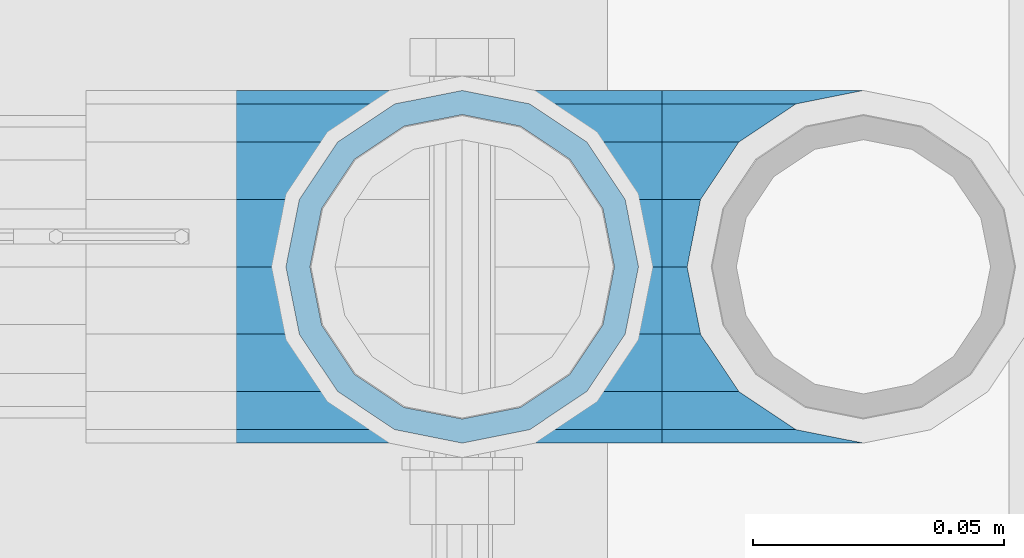
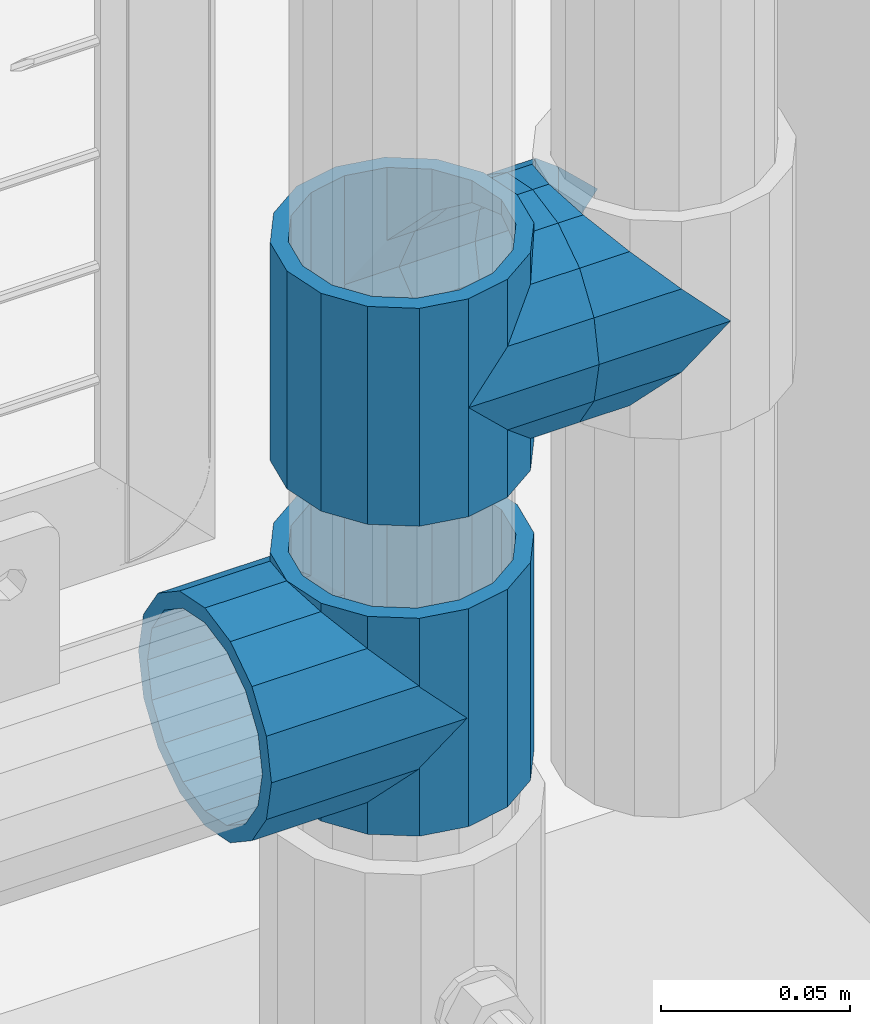
# One storey, part 149 of 219: 5 beams.
"""IFC2X3 building model written with IfcOpenShell, lengths in millimetres."""

import ifcopenshell
import ifcopenshell.guid

model = None  # the IFC model being written
_history = None  # IfcOwnerHistory: only IFC2X3 demands one
_inside = {}  # id of a spatial element -> (the spatial element, [elements in it])
_under = {}  # id of a project, library or spatial element -> (it, [spatial elements below it])
_declared = {}  # id of a project -> (the project, [libraries it declares])
_typed = {}  # id of a type object -> (the type object, [elements of that type])
_made_of = {}  # id of a material, layer set ... -> (it, [elements and type objects made of it])


def new_model(schema):
    """Start an empty IFC model of exactly this schema.

    Asked for "IFC4X3", IfcOpenShell would pick the latest addendum, in which some entities
    have other attributes; the version numbers below select the first issue.
    IFC2X3 requires an IfcOwnerHistory on every rooted entity: one is made here for all.
    """
    global model, _history
    if schema == "IFC4X3":
        model = ifcopenshell.file(schema_version=(4, 3, 0, 0))
    else:
        model = ifcopenshell.file(schema=schema)
    _inside.clear()
    _under.clear()
    _declared.clear()
    _typed.clear()
    _made_of.clear()
    _history = None
    if model.schema == "IFC2X3":
        org = make("IfcOrganization", Name="unknown")
        user = make(
            "IfcPersonAndOrganization",
            ThePerson=make("IfcPerson", FamilyName="unknown"),
            TheOrganization=org,
        )
        app = make(
            "IfcApplication",
            ApplicationDeveloper=org,
            Version="unknown",
            ApplicationFullName="unknown",
            ApplicationIdentifier="unknown",
        )
        _history = make(
            "IfcOwnerHistory",
            OwningUser=user,
            OwningApplication=app,
            ChangeAction="ADDED",
            CreationDate=0,
        )
    return model


def make(cls, **values):
    """One entity of the class cls with the attributes given. An attribute that is None is left unset."""
    return model.create_entity(
        cls, **{name: value for name, value in values.items() if value is not None}
    )


def rooted(cls, **values):
    """An entity with a GlobalId (a new one), such as an element, a storey or a relation."""
    return make(cls, GlobalId=ifcopenshell.guid.new(), OwnerHistory=_history, **values)


def si_unit(unit_type, name, prefix=None):
    """IfcSIUnit, for example si_unit("LENGTHUNIT", "METRE", prefix="MILLI")."""
    return make("IfcSIUnit", UnitType=unit_type, Prefix=prefix, Name=name)


def assignment(units):
    """IfcUnitAssignment: the units of a project."""
    return None if units is None else make("IfcUnitAssignment", Units=units)


def point(xyz):
    """IfcCartesianPoint."""
    return None if xyz is None else make("IfcCartesianPoint", Coordinates=xyz)


def direction(xyz):
    """IfcDirection."""
    return None if xyz is None else make("IfcDirection", DirectionRatios=xyz)


def frame(location, z_axis=None, x_axis=None):
    """IfcAxis2Placement3D, a coordinate frame: its origin and axes. An axis left out is left unset."""
    return make(
        "IfcAxis2Placement3D",
        Location=point(location),
        Axis=direction(z_axis),
        RefDirection=direction(x_axis),
    )


def origin_with_axes():
    """The frame at (0, 0, 0) with the z axis (0, 0, 1) and the x axis (1, 0, 0) written out."""
    return frame((0.0, 0.0, 0.0), z_axis=(0.0, 0.0, 1.0), x_axis=(1.0, 0.0, 0.0))


def place(relative_to, where):
    """IfcLocalPlacement: puts the frame where relative to a parent placement (None: the world)."""
    return make(
        "IfcLocalPlacement", PlacementRelTo=relative_to, RelativePlacement=where
    )


def context(
    kind, dimensions, precision=None, world=None, true_north=None, identifier=None
):
    """IfcGeometricRepresentationContext, for example the 3D "Model" context."""
    return make(
        "IfcGeometricRepresentationContext",
        ContextIdentifier=identifier,
        ContextType=kind,
        CoordinateSpaceDimension=dimensions,
        Precision=precision,
        WorldCoordinateSystem=world,
        TrueNorth=true_north,
    )


def subcontext(parent, identifier, kind, view, scale=None):
    """IfcGeometricRepresentationSubContext, for example "Body" below "Model"."""
    return make(
        "IfcGeometricRepresentationSubContext",
        ContextIdentifier=identifier,
        ContextType=kind,
        ParentContext=parent,
        TargetScale=scale,
        TargetView=view,
    )


def project(units=None, contexts=None):
    """IfcProject with its units and contexts."""
    return rooted(
        "IfcProject",
        Name="project",
        RepresentationContexts=contexts,
        UnitsInContext=assignment(units),
    )


def spatial(cls, under=None, at=None, **own):
    """A site, building, storey or space (cls), placed at a placement, below another one or the project."""
    s = rooted(cls, ObjectPlacement=at, **own)
    if under is not None:
        _under.setdefault(under.id(), (under, []))[1].append(s)
    return s


def faces_of(points, faces, orient=None, outer=None):
    """IfcFace entities. A face is a list of loops; a loop is a list of indices into points, from 0.

    orient and outer hold one flag for each loop. By default every Orientation is true, the
    first loop of a face is its IfcFaceOuterBound and the others are IfcFaceBound.
    """
    made = []
    for i, loops in enumerate(faces):
        bounds = []
        for j, loop in enumerate(loops):
            is_outer = j == 0 if outer is None else outer[i][j]
            bounds.append(
                make(
                    "IfcFaceOuterBound" if is_outer else "IfcFaceBound",
                    Bound=make("IfcPolyLoop", Polygon=[points[k] for k in loop]),
                    Orientation=True if orient is None else orient[i][j],
                )
            )
        made.append(make("IfcFace", Bounds=bounds))
    return made


def faceted_brep(points, faces, orient=None, outer=None, voids=None):
    """IfcFacetedBrep: a solid bounded by flat faces; with voids (closed shells), ...WithVoids."""
    shared = [point(p) for p in points]
    hull = make("IfcClosedShell", CfsFaces=faces_of(shared, faces, orient, outer))
    if voids is None:
        return make("IfcFacetedBrep", Outer=hull)
    return make(
        "IfcFacetedBrepWithVoids",
        Outer=hull,
        Voids=[
            make(cls, CfsFaces=faces_of(shared, fs, o, b)) for cls, fs, o, b in voids
        ],
    )


def shape(context_of_items, identifier, shape_type, items):
    """IfcShapeRepresentation: the items that make up one representation, for example the "Body"."""
    return make(
        "IfcShapeRepresentation",
        ContextOfItems=context_of_items,
        RepresentationIdentifier=identifier,
        RepresentationType=shape_type,
        Items=items,
    )


def material(Name=None, Category=None):
    """IfcMaterial."""
    return make("IfcMaterial", Name=Name, Category=Category)


def made_of(thing, what):
    """Note that an element or type object is made of a material, layer set ...; save() writes the relation."""
    if what is not None:
        _made_of.setdefault(what.id(), (what, []))[1].append(thing)
    return thing


def type_object(cls, material=None, **own):
    """A type object (cls), such as IfcWallType, which elements share."""
    return made_of(rooted(cls, **own), material)


def element(
    cls,
    number,
    at=None,
    inside=None,
    cuts=None,
    type_object=None,
    material=None,
    context=None,
    identifier="Body",
    shape_type=None,
    held_by="IfcProductDefinitionShape",
    body=None,
    shapes=None,
    **own,
):
    """One element of the class cls, such as IfcWall. Its Tag is "e" and its number.

    at: its placement. inside: the storey or other place that contains it. cuts: it is an
    opening in that element (IfcRelVoidsElement). A single representation is given by context,
    identifier, shape_type and body (its items); several are given by shapes. held_by: the class
    of the entity that holds the representations. save() writes the other relations.
    """
    e = rooted(cls, Tag="e%d" % number, ObjectPlacement=at, **own)
    if body is not None:
        shapes = [shape(context, identifier, shape_type, body)]
    if shapes is not None:
        e.Representation = make(held_by, Representations=shapes)
    if inside is not None:
        _inside.setdefault(inside.id(), (inside, []))[1].append(e)
    if cuts is not None:
        rooted(
            "IfcRelVoidsElement", RelatingBuildingElement=cuts, RelatedOpeningElement=e
        )
    if type_object is not None:
        _typed.setdefault(type_object.id(), (type_object, []))[1].append(e)
    return made_of(e, material)


def aggregate(whole, parts):
    """IfcRelAggregates: a whole, such as a stair, and the parts it consists of."""
    return rooted("IfcRelAggregates", RelatingObject=whole, RelatedObjects=parts)


def save(model, path):
    """Write the relations noted so far, then the file.

    IfcRelAggregates (storeys below a building ...), IfcRelContainedInSpatialStructure (elements
    in a storey), IfcRelDefinesByType, IfcRelAssociatesMaterial and IfcRelDeclares: one each for
    every whole, place, type object, material and project.
    """
    for whole, parts in _under.values():
        aggregate(whole, parts)
    for where, things in _inside.values():
        rooted(
            "IfcRelContainedInSpatialStructure",
            RelatedElements=things,
            RelatingStructure=where,
        )
    for kind, things in _typed.values():
        rooted("IfcRelDefinesByType", RelatedObjects=things, RelatingType=kind)
    for what, things in _made_of.values():
        rooted("IfcRelAssociatesMaterial", RelatedObjects=things, RelatingMaterial=what)
    for by, libraries in _declared.values():
        rooted("IfcRelDeclares", RelatingContext=by, RelatedDefinitions=libraries)
    model.write(path)


model = new_model("IFC2X3")

# Units and contexts
model_context = context("Model", 3, precision=1e-05, world=origin_with_axes())
body_context = subcontext(model_context, "Body", "Model", "MODEL_VIEW")
ifc_project = project(units=[si_unit("LENGTHUNIT", "METRE", prefix="MILLI"), si_unit("AREAUNIT", "SQUARE_METRE"), si_unit("VOLUMEUNIT", "CUBIC_METRE"), si_unit("MASSUNIT", "GRAM", prefix="KILO"), si_unit("TIMEUNIT", "SECOND"), si_unit("PLANEANGLEUNIT", "RADIAN"), si_unit("SOLIDANGLEUNIT", "STERADIAN"), si_unit("THERMODYNAMICTEMPERATUREUNIT", "DEGREE_CELSIUS"), si_unit("LUMINOUSINTENSITYUNIT", "LUMEN")], contexts=[model_context])

# Site, building, storey
site_placement = place(None, origin_with_axes())
site = spatial("IfcSite", under=ifc_project, at=site_placement, CompositionType="ELEMENT")
building_placement = place(site_placement, origin_with_axes())
building = spatial("IfcBuilding", under=site, at=building_placement, Name="Standard", CompositionType="ELEMENT")
storey_placement = place(building_placement, origin_with_axes())
storey = spatial("IfcBuildingStorey", under=building, at=storey_placement, Name="Undefined", CompositionType="ELEMENT", Elevation=0.0)

# Beams
ifc_material = material(Name="Misc_Undefined")
beam_type = type_object("IfcBeamType", PredefinedType="NOTDEFINED")
beam_1_placement = place(storey_placement, frame((13431.0, 31664.5, 298.670000000001), z_axis=(0.0, 1.0, 0.0), x_axis=(-1.0, 0.0, 0.0)))
element("IfcBeam", 1, at=beam_1_placement, inside=storey, type_object=beam_type, material=ifc_material, context=body_context, shape_type="Brep", body=[
    faceted_brep([(0.0, 0.0, -35.1500000000015), (13.4513226476338, -13.4513226476329, -32.4743655677703), (13.4513226476338, 13.4513226476329, -32.4743655677703), (27.1226768591096, -21.4606908090117, 21.46069080901), (32.4743655677721, -26.8123795176755, 13.4513226476338), (32.4743655677721, -32.4743655677717, 13.4513226476338), (24.8548033587067, -24.8548033587072, 24.8548033587067), (24.8548033587067, -16.3810424080013, 24.8548033587067), (32.8397438117172, -28.0397438117175, 11.614442172282), (35.1499999999996, -30.35, 0.0), (35.1499999999996, -35.15, 0.0), (32.4743655677721, -26.8123795176712, -13.4513226476338), (32.4743655677721, -32.4743655677717, -13.4513226476338), (32.8397438117172, -28.0397438117175, -11.614442172282), (24.8548033587067, -16.3810424080013, -24.8548033587067), (24.8548033587067, -24.8548033587072, -24.8548033587067), (27.1226768591077, -21.4606908090117, -21.46069080901), (20.0882031229739, -11.6144421722805, -28.0397438117179), (16.6306603983649, 0.0, -30.3499999999985), (20.0882031229739, 11.6144421722805, -28.0397438117179), (24.8548033587067, 16.3810424080013, -24.8548033587067), (24.8548033587067, 24.8548033587072, -24.8548033587067), (27.1226768591077, 21.4606908090117, -21.46069080901), (32.4743655677721, 26.8123795176755, -13.4513226476338), (32.4743655677721, 32.4743655677717, -13.4513226476338), (32.8397438117172, 28.0397438117175, -11.614442172282), (35.1499999999996, 30.35, 0.0), (35.1499999999996, 35.15, 0.0), (32.8397438117172, 28.0397438117175, 11.614442172282), (32.4743655677721, 26.8123795176755, 13.4513226476338), (32.4743655677721, 32.4743655677717, 13.4513226476338), (27.1226768591096, 21.4606908090117, 21.46069080901), (24.8548033587067, 16.3810424080078, 24.8548033587067), (24.8548033587067, 24.8548033587072, 24.8548033587067), (0.0, 0.0, 35.1500000000015), (13.4513226476338, 13.4513226476329, 32.4743655677703), (13.4513226476338, -13.4513226476329, 32.4743655677703), (20.0882031229849, 11.6144421722805, 28.0397438117179), (16.6306603983739, 0.0, 30.3499999999985), (20.0882031229849, -11.6144421722805, 28.0397438117179), (60.1499999999996, -35.15, 0.0), (60.1499999999996, -32.4743655677717, 13.4513226476338), (60.1499999999996, -24.8548033587072, 24.8548033587067), (60.1499999999996, -13.4513226476329, 32.4743655677703), (60.1499999999996, 0.0, 35.1500000000015), (60.1499999999996, -24.8548033587072, -24.8548033587067), (60.1499999999996, -32.4743655677717, -13.4513226476338), (60.1499999999996, -13.4513226476329, -32.4743655677703), (60.1499999999996, 0.0, -35.1500000000015), (60.1499999999996, 13.4513226476329, -32.4743655677703), (60.1499999999996, 24.8548033587072, -24.8548033587067), (60.1499999999996, 32.4743655677717, -13.4513226476338), (60.1499999999996, 35.15, 0.0), (60.1499999999996, 32.4743655677717, 13.4513226476338), (60.1499999999996, 24.8548033587072, 24.8548033587067), (60.1499999999996, 13.4513226476329, 32.4743655677703), (60.1499999999996, -21.4606908090117, 21.46069080901), (60.1499999999996, -11.6144421722805, 28.0397438117179), (60.1499999999996, 0.0, 30.3499999999985), (60.1499999999996, 11.6144421722805, 28.0397438117179), (60.1499999999996, 21.4606908090117, 21.46069080901), (60.1499999999996, 28.0397438117175, 11.614442172282), (60.1499999999996, 30.35, 0.0), (60.1499999999996, 28.0397438117175, -11.614442172282), (60.1499999999996, 21.4606908090117, -21.46069080901), (60.1499999999996, 11.6144421722805, -28.0397438117179), (60.1499999999996, 0.0, -30.3499999999985), (60.1499999999996, -11.6144421722805, -28.0397438117179), (60.1499999999996, -21.4606908090117, -21.46069080901), (60.1499999999996, -28.0397438117175, -11.614442172282), (60.1499999999996, -30.35, 0.0), (60.1499999999996, -28.0397438117175, 11.614442172282)], [[[0, 1, 2]], [[3, 4, 5, 6, 7]], [[8, 9, 10, 5, 4]], [[11, 12, 10, 9, 13]], [[14, 15, 12, 11, 16]], [[2, 1, 15, 14, 17, 18, 19, 20, 21]], [[21, 20, 22, 23, 24]], [[24, 23, 25, 26, 27]], [[27, 26, 28, 29, 30]], [[30, 29, 31, 32, 33]], [[34, 35, 36]], [[33, 32, 37, 38, 39, 7, 6, 36, 35]], [[40, 41, 5, 10]], [[41, 42, 6, 5]], [[42, 43, 36, 6]], [[43, 44, 34, 36]], [[45, 46, 12, 15]], [[47, 45, 15, 1]], [[48, 47, 1, 0]], [[49, 48, 0, 2]], [[50, 49, 2, 21]], [[51, 50, 21, 24]], [[52, 51, 24, 27]], [[53, 52, 27, 30]], [[54, 53, 30, 33]], [[55, 54, 33, 35]], [[44, 55, 35, 34]], [[46, 40, 10, 12]], [[45, 47, 48, 49, 50, 51, 52, 53, 54, 55, 44, 43, 42, 41, 40, 46], [56, 57, 58, 59, 60, 61, 62, 63, 64, 65, 66, 67, 68, 69, 70, 71]], [[59, 58, 38, 37]], [[31, 60, 59, 37, 32]], [[28, 61, 60, 31, 29]], [[62, 61, 28, 26]], [[63, 62, 26, 25]], [[64, 63, 25, 23, 22]], [[65, 64, 22, 20, 19]], [[66, 65, 19, 18]], [[67, 66, 18, 17]], [[16, 68, 67, 17, 14]], [[13, 69, 68, 16, 11]], [[70, 69, 13, 9]], [[71, 70, 9, 8]], [[56, 71, 8, 4, 3]], [[57, 56, 3, 7, 39]], [[58, 57, 39, 38]]]),
])
beam_2_placement = place(storey_placement, frame((13431.0, 31664.5, 333.820000000001), z_axis=(1.0, 0.0, 0.0), x_axis=(0.0, 0.0, -1.0)))
element("IfcBeam", 2, at=beam_2_placement, inside=storey, type_object=beam_type, material=ifc_material, context=body_context, shape_type="Brep", body=[
    faceted_brep([(46.7644421722801, 28.0397438117179, -11.6144421722802), (46.7644421722801, 28.0397438117179, -20.0882031229849), (51.5310424080006, 24.8548033587067, -24.8548033587067), (56.6106908090114, 21.46069080901, -27.1226768591096), (56.6106908090114, 21.46069080901, -21.4606908090118), (61.9623795176703, 13.4513226476338, -32.4743655677721), (63.1897438117172, 11.614442172282, -32.8397438117172), (63.1897438117172, 11.614442172282, -28.0397438117179), (65.4999999999997, 0.0, -35.1499999999996), (65.4999999999997, 0.0, -30.3500000000004), (63.1897438117172, -11.614442172282, -32.839743811719), (63.1897438117172, -11.614442172282, -28.0397438117179), (61.9623795176747, -13.4513226476338, -32.4743655677721), (56.6106908090114, -21.46069080901, -27.1226768591077), (56.6106908090114, -21.46069080901, -21.4606908090118), (51.5310424080006, -24.8548033587067, -24.8548033587067), (46.7644421722801, -28.0397438117179, -20.0882031229739), (46.7644421722801, -28.0397438117179, -11.6144421722802), (35.1499999999996, -30.3499999999985, -16.6306603983649), (35.1499999999996, -30.35, 0.0), (23.5355578277191, -28.0397438117179, -20.0882031229739), (23.5355578277191, -28.0397438117179, -11.6144421722802), (18.7689575919921, -24.8548033587067, -24.8548033587067), (13.6893091909879, -21.46069080901, -27.1226768591077), (13.6893091909879, -21.46069080901, -21.4606908090118), (8.33762048232455, -13.4513226476338, -32.4743655677721), (7.11025618828211, -11.614442172282, -32.839743811719), (7.11025618828211, -11.614442172282, -28.0397438117179), (4.79999999999961, 0.0, -35.1499999999996), (4.79999999999961, 0.0, -30.3500000000004), (7.11025618828211, 11.614442172282, -32.8397438117172), (7.11025618828211, 11.614442172282, -28.0397438117179), (8.33762048232455, 13.4513226476338, -32.4743655677721), (13.6893091909879, 21.46069080901, -27.1226768591096), (13.6893091909879, 21.46069080901, -21.4606908090118), (18.7689575919987, 24.8548033587067, -24.8548033587067), (23.5355578277192, 28.0397438117179, -20.0882031229849), (23.5355578277192, 28.0397438117179, -11.6144421722802), (35.1499999999996, 30.3499999999985, -16.6306603983739), (35.1499999999996, 30.35, 0.0), (0.0, 32.4743655677703, -13.4513226476338), (0.0, 35.1500000000015, 0.0), (70.2999999999993, 35.1500000000015, 0.0), (70.2999999999993, 32.4743655677703, -13.4513226476338), (0.0, 32.4743655677703, 13.4513226476338), (70.2999999999993, 32.4743655677703, 13.4513226476338), (0.0, 24.8548033587067, 24.8548033587067), (70.2999999999993, 24.8548033587067, 24.8548033587067), (0.0, 13.4513226476338, 32.4743655677721), (70.2999999999993, 13.4513226476338, 32.4743655677721), (0.0, 0.0, 35.1500000000015), (70.2999999999993, 0.0, 35.1499999999996), (0.0, -13.4513226476338, 32.4743655677721), (70.2999999999993, -13.4513226476338, 32.4743655677721), (0.0, -24.8548033587067, 24.8548033587067), (70.2999999999993, -24.8548033587067, 24.8548033587067), (0.0, -32.4743655677703, 13.4513226476338), (70.2999999999993, -32.4743655677703, 13.4513226476338), (0.0, -35.1500000000015, 0.0), (70.2999999999993, -35.1500000000015, 0.0), (70.2999999999993, -30.3499999999985, 0.0), (70.2999999999993, -28.0397438117179, -11.6144421722802), (70.2999999999993, -21.46069080901, -21.4606908090118), (70.2999999999993, -11.614442172282, -28.0397438117179), (70.2999999999993, 0.0, -30.3500000000004), (70.2999999999993, 11.614442172282, -28.0397438117179), (70.2999999999993, 21.46069080901, -21.4606908090118), (70.2999999999993, 28.0397438117179, -11.6144421722802), (0.0, -28.0397438117179, -11.6144421722802), (0.0, -30.3499999999985, 0.0), (0.0, -21.46069080901, -21.4606908090118), (0.0, -11.614442172282, -28.0397438117179), (0.0, 0.0, -30.3500000000004), (0.0, 11.614442172282, -28.0397438117179), (0.0, 21.46069080901, -21.4606908090118), (0.0, 28.0397438117179, -11.6144421722802), (0.0, 30.3499999999985, 0.0), (70.2999999999993, 30.3499999999985, 0.0), (0.0, 28.0397438117179, 11.6144421722802), (70.2999999999993, 28.0397438117179, 11.6144421722802), (0.0, 21.46069080901, 21.4606908090118), (70.2999999999993, 21.46069080901, 21.4606908090118), (0.0, 11.614442172282, 28.0397438117179), (70.2999999999993, 11.614442172282, 28.0397438117179), (0.0, 0.0, 30.3500000000004), (70.2999999999993, 0.0, 30.3500000000004), (0.0, -11.614442172282, 28.0397438117179), (70.2999999999993, -11.614442172282, 28.0397438117179), (0.0, -21.46069080901, 21.4606908090118), (70.2999999999993, -21.46069080901, 21.4606908090118), (0.0, -28.0397438117179, 11.6144421722802), (70.2999999999993, -28.0397438117179, 11.6144421722802), (70.2999999999993, -24.8548033587067, -24.8548033587067), (70.2999999999993, -13.4513226476338, -32.4743655677721), (70.2999999999993, 0.0, -35.1499999999996), (70.2999999999993, 13.4513226476338, -32.4743655677721), (70.2999999999993, 24.8548033587067, -24.8548033587067), (70.2999999999993, -32.4743655677703, -13.4513226476338), (0.0, -32.4743655677703, -13.4513226476338), (0.0, 24.8548033587067, -24.8548033587067), (0.0, 13.4513226476338, -32.4743655677721), (0.0, 0.0, -35.1500000000015), (0.0, -13.4513226476338, -32.4743655677721), (0.0, -24.8548033587067, -24.8548033587067)], [[[0, 1, 2, 3, 4]], [[4, 3, 5, 6, 7]], [[7, 6, 8, 9]], [[9, 8, 10, 11]], [[11, 10, 12, 13, 14]], [[14, 13, 15, 16, 17]], [[17, 16, 18, 19]], [[19, 18, 20, 21]], [[21, 20, 22, 23, 24]], [[24, 23, 25, 26, 27]], [[27, 26, 28, 29]], [[29, 28, 30, 31]], [[31, 30, 32, 33, 34]], [[34, 33, 35, 36, 37]], [[37, 36, 38, 39]], [[39, 38, 1, 0]], [[40, 41, 42, 43]], [[41, 44, 45, 42]], [[44, 46, 47, 45]], [[46, 48, 49, 47]], [[48, 50, 51, 49]], [[50, 52, 53, 51]], [[52, 54, 55, 53]], [[54, 56, 57, 55]], [[56, 58, 59, 57]], [[60, 61, 17, 19]], [[61, 62, 14, 17]], [[62, 63, 11, 14]], [[63, 64, 9, 11]], [[64, 65, 7, 9]], [[65, 66, 4, 7]], [[66, 67, 0, 4]], [[68, 69, 19, 21]], [[70, 68, 21, 24]], [[71, 70, 24, 27]], [[72, 71, 27, 29]], [[73, 72, 29, 31]], [[74, 73, 31, 34]], [[75, 74, 34, 37]], [[76, 75, 37, 39]], [[67, 77, 39, 0]], [[78, 76, 39, 77, 79]], [[80, 78, 79, 81]], [[82, 80, 81, 83]], [[84, 82, 83, 85]], [[86, 84, 85, 87]], [[88, 86, 87, 89]], [[90, 88, 89, 91]], [[19, 69, 90, 91, 60]], [[92, 93, 94, 95, 96, 43, 42, 45, 47, 49, 51, 53, 55, 57, 59, 97], [89, 87, 85, 83, 81, 79, 77, 67, 66, 65, 64, 63, 62, 61, 60, 91]], [[58, 98, 97, 59]], [[56, 54, 52, 50, 48, 46, 44, 41, 40, 99, 100, 101, 102, 103, 98, 58], [68, 70, 71, 72, 73, 74, 75, 76, 78, 80, 82, 84, 86, 88, 90, 69]], [[32, 100, 99, 35, 33]], [[28, 101, 100, 32, 30]], [[102, 101, 28, 26, 25]], [[103, 102, 25, 23, 22]], [[15, 92, 97, 98, 103, 22, 20, 18, 16]], [[12, 93, 92, 15, 13]], [[8, 94, 93, 12, 10]], [[95, 94, 8, 6, 5]], [[96, 95, 5, 3, 2]], [[35, 99, 40, 43, 96, 2, 1, 38, 36]]]),
])
beam_3_placement = place(storey_placement, frame((13431.0, 31664.5, 398.670000000005), z_axis=(0.0, -1.0, 0.0), x_axis=(1.0, 0.0, 0.0)))
element("IfcBeam", 3, at=beam_3_placement, inside=storey, type_object=beam_type, material=ifc_material, context=body_context, shape_type="Brep", body=[
    faceted_brep([(0.0, 0.0, -35.1500000000015), (13.4513226476338, -13.4513226476329, -32.4743655677703), (13.4513226476338, 13.4513226476329, -32.4743655677703), (32.4743655677721, 32.4743655677717, 13.4513226476338), (32.4743655677721, 26.8123795176755, 13.4513226476338), (27.1226768591096, 21.4606908090117, 21.46069080901), (24.8548033587067, 16.3810424080078, 24.8548033587067), (24.8548033587067, 24.8548033587072, 24.8548033587067), (0.0, 0.0, 35.1500000000015), (13.4513226476338, 13.4513226476329, 32.4743655677703), (13.4513226476338, -13.4513226476329, 32.4743655677703), (20.0882031229849, 11.6144421722805, 28.0397438117179), (16.6306603983739, 0.0, 30.3499999999985), (20.0882031229849, -11.6144421722805, 28.0397438117179), (24.8548033587067, -16.3810424080013, 24.8548033587067), (24.8548033587067, -24.8548033587072, 24.8548033587067), (27.1226768591096, -21.4606908090117, 21.46069080901), (32.4743655677721, -26.8123795176755, 13.4513226476338), (32.4743655677721, -32.4743655677717, 13.4513226476338), (32.8397438117172, -28.0397438117175, 11.614442172282), (35.1499999999996, -30.35, 0.0), (35.1499999999996, -35.15, 0.0), (32.4743655677721, -26.8123795176712, -13.4513226476338), (32.4743655677721, -32.4743655677717, -13.4513226476338), (32.8397438117172, -28.0397438117175, -11.614442172282), (24.8548033587067, -16.3810424080013, -24.8548033587067), (24.8548033587067, -24.8548033587072, -24.8548033587067), (27.1226768591077, -21.4606908090117, -21.46069080901), (20.0882031229739, -11.6144421722805, -28.0397438117179), (16.6306603983649, 0.0, -30.3499999999985), (20.0882031229739, 11.6144421722805, -28.0397438117179), (24.8548033587067, 16.3810424080013, -24.8548033587067), (24.8548033587067, 24.8548033587072, -24.8548033587067), (27.1226768591077, 21.4606908090117, -21.46069080901), (32.4743655677721, 26.8123795176755, -13.4513226476338), (32.4743655677721, 32.4743655677717, -13.4513226476338), (32.8397438117172, 28.0397438117175, -11.614442172282), (35.1499999999996, 30.35, 0.0), (35.1499999999996, 35.15, 0.0), (32.8397438117172, 28.0397438117175, 11.614442172282), (40.1500000000015, -35.15, 0.0), (40.1500000000015, -32.4743655677717, 13.4513226476338), (40.1500000000015, -24.8548033587072, 24.8548033587067), (40.1500000000015, -13.4513226476329, 32.4743655677703), (40.1500000000015, 0.0, 35.1500000000015), (40.1500000000015, 13.4513226476329, 32.4743655677703), (40.1500000000015, 24.8548033587072, 24.8548033587067), (40.1500000000015, 32.4743655677717, 13.4513226476338), (40.1500000000015, 35.15, 0.0), (40.1500000000015, -24.8548033587072, -24.8548033587067), (40.1500000000015, -32.4743655677717, -13.4513226476338), (40.1500000000015, -13.4513226476329, -32.4743655677703), (40.1500000000015, 0.0, -35.1500000000015), (40.1500000000015, 13.4513226476329, -32.4743655677703), (40.1500000000015, 24.8548033587072, -24.8548033587067), (40.1500000000015, 32.4743655677717, -13.4513226476338), (40.1500000000015, -21.4606908090117, 21.46069080901), (40.1500000000015, -11.6144421722805, 28.0397438117179), (40.1500000000015, 0.0, 30.3499999999985), (40.1500000000015, 11.6144421722805, 28.0397438117179), (40.1500000000015, 21.4606908090117, 21.46069080901), (40.1500000000015, 28.0397438117175, 11.614442172282), (40.1500000000015, 30.35, 0.0), (40.1500000000015, 28.0397438117175, -11.614442172282), (40.1500000000015, 21.4606908090117, -21.46069080901), (40.1500000000015, 11.6144421722805, -28.0397438117179), (40.1500000000015, 0.0, -30.3499999999985), (40.1500000000015, -11.6144421722805, -28.0397438117179), (40.1500000000015, -21.4606908090117, -21.46069080901), (40.1500000000015, -28.0397438117175, -11.614442172282), (40.1500000000015, -30.35, 0.0), (40.1500000000015, -28.0397438117175, 11.614442172282)], [[[0, 1, 2]], [[3, 4, 5, 6, 7]], [[8, 9, 10]], [[7, 6, 11, 12, 13, 14, 15, 10, 9]], [[16, 17, 18, 15, 14]], [[19, 20, 21, 18, 17]], [[22, 23, 21, 20, 24]], [[25, 26, 23, 22, 27]], [[2, 1, 26, 25, 28, 29, 30, 31, 32]], [[32, 31, 33, 34, 35]], [[35, 34, 36, 37, 38]], [[38, 37, 39, 4, 3]], [[40, 41, 18, 21]], [[41, 42, 15, 18]], [[42, 43, 10, 15]], [[43, 44, 8, 10]], [[44, 45, 9, 8]], [[45, 46, 7, 9]], [[46, 47, 3, 7]], [[47, 48, 38, 3]], [[49, 50, 23, 26]], [[51, 49, 26, 1]], [[52, 51, 1, 0]], [[53, 52, 0, 2]], [[54, 53, 2, 32]], [[55, 54, 32, 35]], [[48, 55, 35, 38]], [[50, 40, 21, 23]], [[49, 51, 52, 53, 54, 55, 48, 47, 46, 45, 44, 43, 42, 41, 40, 50], [56, 57, 58, 59, 60, 61, 62, 63, 64, 65, 66, 67, 68, 69, 70, 71]], [[63, 62, 37, 36]], [[33, 64, 63, 36, 34]], [[30, 65, 64, 33, 31]], [[66, 65, 30, 29]], [[67, 66, 29, 28]], [[68, 67, 28, 25, 27]], [[69, 68, 27, 22, 24]], [[70, 69, 24, 20]], [[71, 70, 20, 19]], [[16, 56, 71, 19, 17]], [[13, 57, 56, 16, 14]], [[58, 57, 13, 12]], [[59, 58, 12, 11]], [[60, 59, 11, 6, 5]], [[61, 60, 5, 4, 39]], [[62, 61, 39, 37]]]),
])
beam_4_placement = place(storey_placement, frame((13511.0, 31664.5, 398.670000000005), z_axis=(0.0, 1.0, 0.0), x_axis=(-1.0, 0.0, 0.0)))
element("IfcBeam", 4, at=beam_4_placement, inside=storey, type_object=beam_type, material=ifc_material, context=body_context, shape_type="Brep", body=[
    faceted_brep([(0.0, 0.0, -35.1500000000015), (13.4513226476338, -13.4513226476329, -32.4743655677703), (13.4513226476338, 13.4513226476329, -32.4743655677703), (27.1226768591096, -21.4606908090117, 21.46069080901), (32.4743655677721, -26.8123795176755, 13.4513226476338), (32.4743655677721, -32.4743655677717, 13.4513226476338), (24.8548033587067, -24.8548033587072, 24.8548033587067), (24.8548033587067, -16.3810424080013, 24.8548033587067), (32.8397438117172, -28.0397438117175, 11.614442172282), (35.1499999999996, -30.35, 0.0), (35.1499999999996, -35.15, 0.0), (32.4743655677721, -26.8123795176712, -13.4513226476338), (32.4743655677721, -32.4743655677717, -13.4513226476338), (32.8397438117172, -28.0397438117175, -11.614442172282), (24.8548033587067, -16.3810424080013, -24.8548033587067), (24.8548033587067, -24.8548033587072, -24.8548033587067), (27.1226768591077, -21.4606908090117, -21.46069080901), (20.0882031229739, -11.6144421722805, -28.0397438117179), (16.6306603983649, 0.0, -30.3499999999985), (20.0882031229739, 11.6144421722805, -28.0397438117179), (24.8548033587067, 16.3810424080013, -24.8548033587067), (24.8548033587067, 24.8548033587072, -24.8548033587067), (27.1226768591077, 21.4606908090117, -21.46069080901), (32.4743655677721, 26.8123795176755, -13.4513226476338), (32.4743655677721, 32.4743655677717, -13.4513226476338), (32.8397438117172, 28.0397438117175, -11.614442172282), (35.1499999999996, 30.35, 0.0), (35.1499999999996, 35.15, 0.0), (32.8397438117172, 28.0397438117175, 11.614442172282), (32.4743655677721, 26.8123795176755, 13.4513226476338), (32.4743655677721, 32.4743655677717, 13.4513226476338), (27.1226768591096, 21.4606908090117, 21.46069080901), (24.8548033587067, 16.3810424080078, 24.8548033587067), (24.8548033587067, 24.8548033587072, 24.8548033587067), (0.0, 0.0, 35.1500000000015), (13.4513226476338, 13.4513226476329, 32.4743655677703), (13.4513226476338, -13.4513226476329, 32.4743655677703), (20.0882031229849, 11.6144421722805, 28.0397438117179), (16.6306603983739, 0.0, 30.3499999999985), (20.0882031229849, -11.6144421722805, 28.0397438117179), (40.1500000000015, -35.15, 0.0), (40.1500000000015, -32.4743655677717, 13.4513226476338), (40.1500000000015, -24.8548033587072, 24.8548033587067), (40.1500000000015, -13.4513226476329, 32.4743655677703), (40.1500000000015, 0.0, 35.1500000000015), (40.1500000000015, -24.8548033587072, -24.8548033587067), (40.1500000000015, -32.4743655677717, -13.4513226476338), (40.1500000000015, -13.4513226476329, -32.4743655677703), (40.1500000000015, 0.0, -35.1500000000015), (40.1500000000015, 13.4513226476329, -32.4743655677703), (40.1500000000015, 24.8548033587072, -24.8548033587067), (40.1500000000015, 32.4743655677717, -13.4513226476338), (40.1500000000015, 35.15, 0.0), (40.1500000000015, 32.4743655677717, 13.4513226476338), (40.1500000000015, 24.8548033587072, 24.8548033587067), (40.1500000000015, 13.4513226476329, 32.4743655677703), (40.1500000000015, -21.4606908090117, 21.46069080901), (40.1500000000015, -11.6144421722805, 28.0397438117179), (40.1500000000015, 0.0, 30.3499999999985), (40.1500000000015, 11.6144421722805, 28.0397438117179), (40.1500000000015, 21.4606908090117, 21.46069080901), (40.1500000000015, 28.0397438117175, 11.614442172282), (40.1500000000015, 30.35, 0.0), (40.1500000000015, 28.0397438117175, -11.614442172282), (40.1500000000015, 21.4606908090117, -21.46069080901), (40.1500000000015, 11.6144421722805, -28.0397438117179), (40.1500000000015, 0.0, -30.3499999999985), (40.1500000000015, -11.6144421722805, -28.0397438117179), (40.1500000000015, -21.4606908090117, -21.46069080901), (40.1500000000015, -28.0397438117175, -11.614442172282), (40.1500000000015, -30.35, 0.0), (40.1500000000015, -28.0397438117175, 11.614442172282)], [[[0, 1, 2]], [[3, 4, 5, 6, 7]], [[8, 9, 10, 5, 4]], [[11, 12, 10, 9, 13]], [[14, 15, 12, 11, 16]], [[2, 1, 15, 14, 17, 18, 19, 20, 21]], [[21, 20, 22, 23, 24]], [[24, 23, 25, 26, 27]], [[27, 26, 28, 29, 30]], [[30, 29, 31, 32, 33]], [[34, 35, 36]], [[33, 32, 37, 38, 39, 7, 6, 36, 35]], [[40, 41, 5, 10]], [[41, 42, 6, 5]], [[42, 43, 36, 6]], [[43, 44, 34, 36]], [[45, 46, 12, 15]], [[47, 45, 15, 1]], [[48, 47, 1, 0]], [[49, 48, 0, 2]], [[50, 49, 2, 21]], [[51, 50, 21, 24]], [[52, 51, 24, 27]], [[53, 52, 27, 30]], [[54, 53, 30, 33]], [[55, 54, 33, 35]], [[44, 55, 35, 34]], [[46, 40, 10, 12]], [[45, 47, 48, 49, 50, 51, 52, 53, 54, 55, 44, 43, 42, 41, 40, 46], [56, 57, 58, 59, 60, 61, 62, 63, 64, 65, 66, 67, 68, 69, 70, 71]], [[59, 58, 38, 37]], [[60, 59, 37, 32, 31]], [[61, 60, 31, 29, 28]], [[62, 61, 28, 26]], [[63, 62, 26, 25]], [[22, 64, 63, 25, 23]], [[19, 65, 64, 22, 20]], [[66, 65, 19, 18]], [[67, 66, 18, 17]], [[68, 67, 17, 14, 16]], [[69, 68, 16, 11, 13]], [[70, 69, 13, 9]], [[71, 70, 9, 8]], [[3, 56, 71, 8, 4]], [[39, 57, 56, 3, 7]], [[58, 57, 39, 38]]]),
])
beam_5_placement = place(storey_placement, frame((13431.0, 31664.5, 433.820000000004), z_axis=(-1.0, 0.0, 0.0), x_axis=(0.0, 0.0, -1.0)))
element("IfcBeam", 5, at=beam_5_placement, inside=storey, type_object=beam_type, material=ifc_material, context=body_context, shape_type="Brep", body=[
    faceted_brep([(13.6893091909879, -21.46069080901, -21.4606908090118), (13.6893091909879, -21.46069080901, -27.1226768591077), (8.33762048232455, -13.4513226476338, -32.4743655677721), (7.11025618828211, -11.614442172282, -32.839743811719), (7.11025618828211, -11.614442172282, -28.0397438117179), (23.5355578277191, -28.0397438117179, -11.6144421722802), (23.5355578277191, -28.0397438117179, -20.0882031229739), (18.7689575919921, -24.8548033587067, -24.8548033587067), (35.1499999999996, -30.35, 0.0), (35.1499999999996, -30.3499999999985, -16.6306603983649), (46.7644421722801, -28.0397438117179, -11.6144421722802), (46.7644421722801, -28.0397438117179, -20.0882031229739), (56.6106908090114, -21.46069080901, -21.4606908090118), (56.6106908090114, -21.46069080901, -27.1226768591077), (51.5310424080006, -24.8548033587067, -24.8548033587067), (63.1897438117172, -11.614442172282, -28.0397438117179), (63.1897438117172, -11.614442172282, -32.839743811719), (61.9623795176747, -13.4513226476338, -32.4743655677721), (65.4999999999997, 0.0, -30.3500000000004), (65.4999999999997, 0.0, -35.1499999999996), (63.1897438117172, 11.614442172282, -28.0397438117179), (63.1897438117172, 11.614442172282, -32.8397438117172), (56.6106908090114, 21.46069080901, -21.4606908090118), (56.6106908090114, 21.46069080901, -27.1226768591096), (61.9623795176703, 13.4513226476338, -32.4743655677721), (46.7644421722801, 28.0397438117179, -11.6144421722802), (46.7644421722801, 28.0397438117179, -20.0882031229849), (51.5310424080006, 24.8548033587067, -24.8548033587067), (35.1499999999996, 30.35, 0.0), (35.1499999999996, 30.3499999999985, -16.6306603983739), (23.5355578277192, 28.0397438117179, -11.6144421722802), (23.5355578277192, 28.0397438117179, -20.0882031229849), (13.6893091909879, 21.46069080901, -21.4606908090118), (13.6893091909879, 21.46069080901, -27.1226768591096), (18.7689575919987, 24.8548033587067, -24.8548033587067), (7.11025618828211, 11.614442172282, -28.0397438117179), (7.11025618828211, 11.614442172282, -32.8397438117172), (8.33762048232455, 13.4513226476338, -32.4743655677721), (4.79999999999961, 0.0, -30.3500000000004), (4.79999999999961, 0.0, -35.1499999999996), (0.0, 21.46069080901, 21.4606908090118), (0.0, 28.0397438117179, 11.6144421722802), (70.2999999999993, 28.0397438117179, 11.6144421722802), (70.2999999999993, 21.46069080901, 21.4606908090118), (0.0, 11.614442172282, 28.0397438117179), (70.2999999999993, 11.614442172282, 28.0397438117179), (0.0, 0.0, 30.3500000000004), (70.2999999999993, 0.0, 30.3500000000004), (0.0, -11.614442172282, 28.0397438117179), (70.2999999999993, -11.614442172282, 28.0397438117179), (0.0, -21.46069080901, 21.4606908090118), (70.2999999999993, -21.46069080901, 21.4606908090118), (0.0, -28.0397438117179, 11.6144421722802), (70.2999999999993, -28.0397438117179, 11.6144421722802), (0.0, -24.8548033587067, -24.8548033587067), (0.0, -13.4513226476338, -32.4743655677721), (0.0, 0.0, -35.1500000000015), (0.0, -32.4743655677703, 13.4513226476338), (0.0, -35.1500000000015, 0.0), (70.2999999999993, -35.1500000000015, 0.0), (70.2999999999993, -32.4743655677703, 13.4513226476338), (0.0, -24.8548033587067, 24.8548033587067), (70.2999999999993, -24.8548033587067, 24.8548033587067), (0.0, -13.4513226476338, 32.4743655677721), (70.2999999999993, -13.4513226476338, 32.4743655677721), (0.0, 0.0, 35.1500000000015), (70.2999999999993, 0.0, 35.1499999999996), (0.0, 13.4513226476338, 32.4743655677721), (70.2999999999993, 13.4513226476338, 32.4743655677721), (0.0, 24.8548033587067, 24.8548033587067), (70.2999999999993, 24.8548033587067, 24.8548033587067), (0.0, 32.4743655677703, 13.4513226476338), (70.2999999999993, 32.4743655677703, 13.4513226476338), (0.0, 35.1500000000015, 0.0), (70.2999999999993, 35.1500000000015, 0.0), (0.0, 32.4743655677703, -13.4513226476338), (70.2999999999993, 32.4743655677703, -13.4513226476338), (70.2999999999993, -13.4513226476338, -32.4743655677721), (70.2999999999993, -24.8548033587067, -24.8548033587067), (70.2999999999993, 0.0, -35.1499999999996), (70.2999999999993, 13.4513226476338, -32.4743655677721), (70.2999999999993, 24.8548033587067, -24.8548033587067), (0.0, 24.8548033587067, -24.8548033587067), (0.0, 13.4513226476338, -32.4743655677721), (70.2999999999993, -32.4743655677703, -13.4513226476338), (0.0, -32.4743655677703, -13.4513226476338), (0.0, -28.0397438117179, -11.6144421722802), (0.0, -21.46069080901, -21.4606908090118), (0.0, -11.614442172282, -28.0397438117179), (0.0, 0.0, -30.3500000000004), (0.0, 11.614442172282, -28.0397438117179), (0.0, 21.46069080901, -21.4606908090118), (0.0, 28.0397438117179, -11.6144421722802), (0.0, 30.3499999999985, 0.0), (0.0, -30.3499999999985, 0.0), (70.2999999999993, 30.3499999999985, 0.0), (70.2999999999993, 28.0397438117179, -11.6144421722802), (70.2999999999993, 21.46069080901, -21.4606908090118), (70.2999999999993, 11.614442172282, -28.0397438117179), (70.2999999999993, 0.0, -30.3500000000004), (70.2999999999993, -11.614442172282, -28.0397438117179), (70.2999999999993, -21.46069080901, -21.4606908090118), (70.2999999999993, -28.0397438117179, -11.6144421722802), (70.2999999999993, -30.3499999999985, 0.0)], [[[0, 1, 2, 3, 4]], [[5, 6, 7, 1, 0]], [[8, 9, 6, 5]], [[10, 11, 9, 8]], [[12, 13, 14, 11, 10]], [[15, 16, 17, 13, 12]], [[18, 19, 16, 15]], [[20, 21, 19, 18]], [[22, 23, 24, 21, 20]], [[25, 26, 27, 23, 22]], [[28, 29, 26, 25]], [[30, 31, 29, 28]], [[32, 33, 34, 31, 30]], [[35, 36, 37, 33, 32]], [[38, 39, 36, 35]], [[4, 3, 39, 38]], [[40, 41, 42, 43]], [[44, 40, 43, 45]], [[46, 44, 45, 47]], [[48, 46, 47, 49]], [[50, 48, 49, 51]], [[52, 50, 51, 53]], [[54, 55, 2, 1, 7]], [[55, 56, 39, 3, 2]], [[57, 58, 59, 60]], [[61, 57, 60, 62]], [[63, 61, 62, 64]], [[65, 63, 64, 66]], [[67, 65, 66, 68]], [[69, 67, 68, 70]], [[71, 69, 70, 72]], [[73, 71, 72, 74]], [[75, 73, 74, 76]], [[17, 77, 78, 14, 13]], [[19, 79, 77, 17, 16]], [[80, 79, 19, 21, 24]], [[81, 80, 24, 23, 27]], [[34, 82, 75, 76, 81, 27, 26, 29, 31]], [[37, 83, 82, 34, 33]], [[39, 56, 83, 37, 36]], [[14, 78, 84, 85, 54, 7, 6, 9, 11]], [[58, 85, 84, 59]], [[57, 61, 63, 65, 67, 69, 71, 73, 75, 82, 83, 56, 55, 54, 85, 58], [86, 87, 88, 89, 90, 91, 92, 93, 41, 40, 44, 46, 48, 50, 52, 94]], [[90, 89, 38, 35]], [[91, 90, 35, 32]], [[92, 91, 32, 30]], [[93, 92, 30, 28]], [[41, 93, 28, 95, 42]], [[96, 95, 28, 25]], [[97, 96, 25, 22]], [[98, 97, 22, 20]], [[99, 98, 20, 18]], [[100, 99, 18, 15]], [[101, 100, 15, 12]], [[102, 101, 12, 10]], [[103, 102, 10, 8]], [[78, 77, 79, 80, 81, 76, 74, 72, 70, 68, 66, 64, 62, 60, 59, 84], [51, 49, 47, 45, 43, 42, 95, 96, 97, 98, 99, 100, 101, 102, 103, 53]], [[8, 94, 52, 53, 103]], [[86, 94, 8, 5]], [[87, 86, 5, 0]], [[88, 87, 0, 4]], [[89, 88, 4, 38]]]),
])

save(model, "model.ifc")
